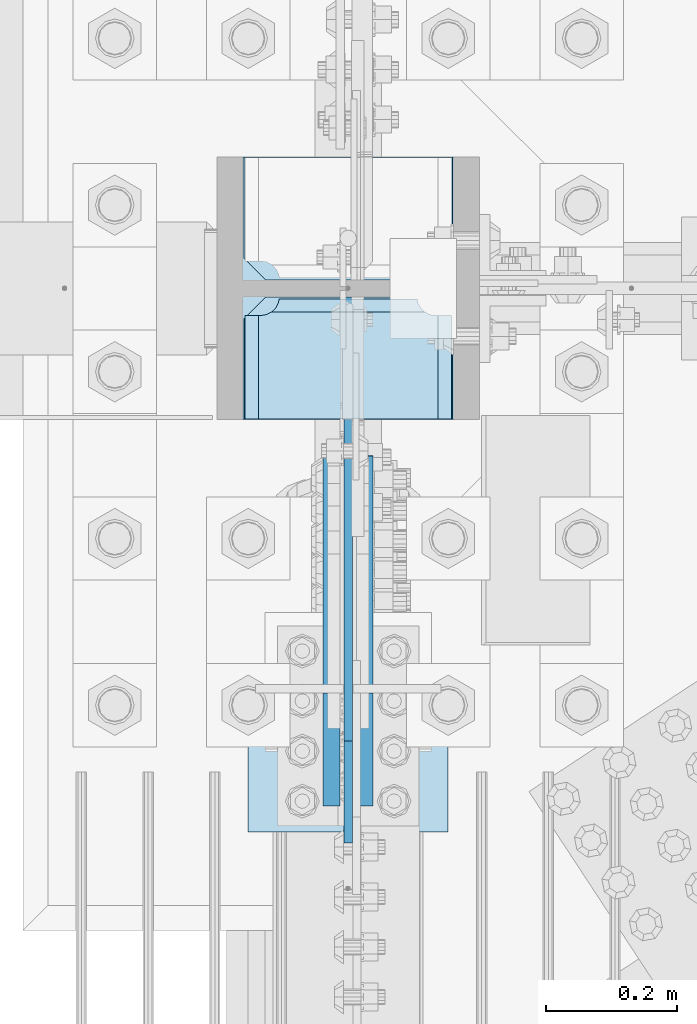
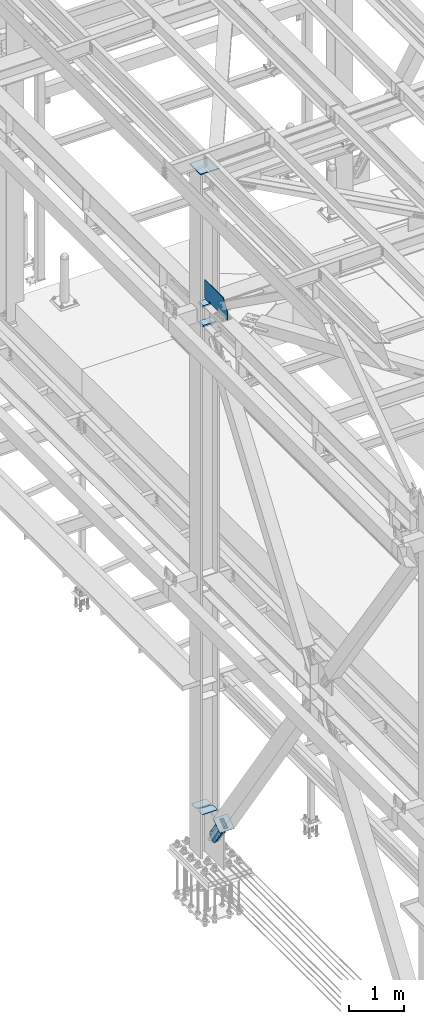
# One storey, part 3363 of 3843: 9 plates, 4 elements without a shape of their own.
"""IFC2X3 building model written with IfcOpenShell, lengths in millimetres."""

from ifc_helpers import new_model, si_unit, frame, origin_with_axes, place, context, subcontext, project, spatial, faceted_brep, material, type_object, element, aggregate, save


model = new_model("IFC2X3")

# Units and contexts
model_context = context("Model", 3, precision=1e-05, world=origin_with_axes())
body_context = subcontext(model_context, "Body", "Model", "MODEL_VIEW")
ifc_project = project(units=[si_unit("LENGTHUNIT", "METRE", prefix="MILLI"), si_unit("AREAUNIT", "SQUARE_METRE"), si_unit("VOLUMEUNIT", "CUBIC_METRE"), si_unit("MASSUNIT", "GRAM", prefix="KILO"), si_unit("TIMEUNIT", "SECOND"), si_unit("PLANEANGLEUNIT", "RADIAN"), si_unit("SOLIDANGLEUNIT", "STERADIAN"), si_unit("THERMODYNAMICTEMPERATUREUNIT", "DEGREE_CELSIUS"), si_unit("LUMINOUSINTENSITYUNIT", "LUMEN")], contexts=[model_context])

# Site, building, storey
site_placement = place(None, origin_with_axes())
site = spatial("IfcSite", under=ifc_project, at=site_placement, CompositionType="ELEMENT")
building_placement = place(site_placement, origin_with_axes())
building = spatial("IfcBuilding", under=site, at=building_placement, Name="Undefined", CompositionType="ELEMENT")
storey_placement = place(building_placement, origin_with_axes())
storey = spatial("IfcBuildingStorey", under=building, at=storey_placement, Name="Undefined", CompositionType="ELEMENT", Elevation=0.0)

# Assembly, plates
assembly_1_placement = place(storey_placement, origin_with_axes())
assembly_1 = element("IfcElementAssembly", 1, at=assembly_1_placement, inside=storey, Name="COLUMN", AssemblyPlace="NOTDEFINED", PredefinedType="RIGID_FRAME")
ifc_material_1 = material(Name="STEEL/A572-50")
plate_type_1 = type_object("IfcPlateType", PredefinedType="NOTDEFINED")
plate_1_placement = place(assembly_1_placement, frame((36575.9999999316, 75615.8000000094, 42468.7999999836), z_axis=(0.0, -1.0, 0.0), x_axis=(0.0, 0.0, 1.0)))
plate_1 = element("IfcPlate", 2, at=plate_1_placement, type_object=plate_type_1, material=ifc_material_1, Name="PLATE", context=body_context, shape_type="Brep", body=[
    faceted_brep([(19.0499992370605, -6.34999999999854, 0.0), (0.0, -6.34999999999854, 19.0499992370605), (0.0, 6.34999999999854, 19.0499992370605), (19.0499992370605, 6.34999999999854, 0.0), (25.4000002071116, -6.34999999999854, 161.925000009447), (25.4000002071116, 6.34999999999854, 161.925000009447), (0.0, 6.34999999999854, 161.925000009447), (0.0, -6.34999999999854, 161.925000009447), (30.260079725158, -6.34999999999854, 162.891729932038), (30.260079725158, 6.34999999999854, 162.891729932038), (34.3802561933117, -6.34999999999854, 165.644743832512), (34.3802561933117, 6.34999999999854, 165.644743832512), (37.1332700937855, -6.34999999999854, 169.764920300666), (37.1332700937855, 6.34999999999854, 169.764920300666), (38.1000000163767, -6.34999999999854, 174.624999818712), (38.1000000163767, 6.34999999999854, 174.624999818712), (38.1000000163767, -6.34999999999854, 200.025000200185), (38.1000000163767, 6.34999999999854, 200.025000200185), (37.1332700937855, -6.34999999999854, 204.885079718231), (37.1332700937855, 6.34999999999854, 204.885079718231), (34.3802561933117, -6.34999999999854, 209.005256186385), (34.3802561933117, 6.34999999999854, 209.005256186385), (30.260079725158, -6.34999999999854, 211.758270086859), (30.260079725158, 6.34999999999854, 211.758270086859), (25.4000002071116, -6.34999999999854, 212.72500000945), (25.4000002071116, 6.34999999999854, 212.72500000945), (12.7000000163753, -6.34999999999854, 212.72500000945), (12.7000000163753, 6.34999999999854, 212.72500000945), (12.7000000163753, -6.34999999999854, 831.912257822361), (12.7000000163753, 6.34999999999854, 831.912257822361), (209.514709617921, -6.34999999999854, 831.912257822361), (209.514709617921, 6.34999999999854, 831.912257822361), (426.693425222751, -6.34999999999854, 677.114662594795), (426.693425222751, 6.34999999999854, 677.114662594795), (426.693425222751, -6.34999999999854, 0.0), (426.693425222751, 6.34999999999854, 0.0)], [[[0, 1, 2, 3]], [[4, 5, 6, 7]], [[8, 9, 5, 4]], [[10, 11, 9, 8]], [[12, 13, 11, 10]], [[14, 15, 13, 12]], [[16, 17, 15, 14]], [[18, 19, 17, 16]], [[20, 21, 19, 18]], [[22, 23, 21, 20]], [[24, 25, 23, 22]], [[25, 24, 26, 27]], [[28, 29, 27, 26]], [[30, 31, 29, 28]], [[30, 32, 33, 31]], [[32, 34, 35, 33]], [[35, 34, 0, 3]], [[6, 5, 9, 11, 13, 15, 17, 19, 21, 23, 25, 27, 29, 31, 33, 35, 3, 2]], [[7, 6, 2, 1]], [[34, 32, 30, 28, 26, 24, 22, 20, 18, 16, 14, 12, 10, 8, 4, 7, 1, 0]]]),
])
plate_type_2 = type_object("IfcPlateType", PredefinedType="NOTDEFINED")
plate_2_placement = place(assembly_1_placement, frame((36415.6625, 75429.2687, 42013.1875), z_axis=(1.0, 0.0, 0.0), x_axis=(0.0, 1.0, 0.0)))
plate_2 = element("IfcPlate", 3, at=plate_2_placement, type_object=plate_type_2, material=ifc_material_1, Name="PLATE", context=body_context, shape_type="Brep", body=[
    faceted_brep([(169.7353359673, 6.12986484301655, 50.1051604685563), (163.413638768514, 17.0792088240414, 43.7834632697632), (163.192342336726, 17.4625000000015, 43.3491445679101), (163.192342336726, 17.4625000000015, 277.325855432093), (163.413638768514, 17.0792088240414, 276.89153673024), (169.7353359673, 6.12986484301655, 270.569839531447), (177.701139149984, -7.66711346669035, 266.511060084209), (183.356300047686, -17.4625000000015, 265.61537059048), (183.356300047686, -17.4625000000015, 55.059629409523), (177.701139149984, -7.66711346669035, 54.1639399157939), (0.0, 17.4625000000015, 297.336542336721), (0.0, -17.4625000000015, 317.500500047689), (157.956299237063, -17.4625000000015, 317.500500047689), (157.956299237063, 17.4625000000015, 297.336542336721), (157.956299237063, 17.4625000000015, 23.3384576632816), (157.956299237063, -17.4625000000015, 3.17449995231436), (0.0, -17.4625000000015, 3.17449995232164), (0.0, 17.4625000000015, 23.3384576632816), (157.956299237063, -17.4625000000015, 293.687500762942), (157.956299237063, 17.4625000000015, 293.687500762942), (159.354859321276, -17.4625000000015, 284.857339912916), (159.354859321276, 17.4625000000015, 284.857339912916), (163.413638768514, -17.4625000000015, 276.89153673024), (169.7353359673, -17.4625000000015, 270.569839531447), (177.701139149984, -17.4625000000015, 266.511060084209), (177.701139149984, -17.4625000000015, 54.1639399157939), (169.7353359673, -17.4625000000015, 50.1051604685563), (163.413638768514, -17.4625000000015, 43.7834632697632), (159.354859321276, -17.4625000000015, 35.8176600870866), (159.354859321276, 17.4625000000015, 35.8176600870866), (157.956299237063, -17.4625000000015, 26.9874992370605), (157.956299237063, 17.4625000000015, 26.9874992370605)], [[[0, 1, 2, 3, 4, 5, 6, 7, 8, 9]], [[10, 11, 12, 13]], [[14, 15, 16, 17]], [[17, 16, 11, 10]], [[18, 19, 13, 12]], [[18, 20, 21, 19]], [[21, 20, 22, 4, 3]], [[22, 23, 5, 4]], [[23, 24, 6, 5]], [[24, 7, 6]], [[25, 9, 8]], [[25, 26, 0, 9]], [[26, 27, 1, 0]], [[27, 28, 29, 2, 1]], [[28, 30, 31, 29]], [[31, 30, 15, 14]], [[29, 31, 14, 17, 10, 13, 19, 21, 3, 2]], [[15, 30, 28, 27, 26, 25, 8, 7, 24, 23, 22, 20, 18, 12, 11, 16]]]),
])
plate_3_placement = place(assembly_1_placement, frame((36415.6625, 75429.2687, 42451.3375), z_axis=(1.0, 0.0, 0.0), x_axis=(0.0, 1.0, 0.0)))
plate_3 = element("IfcPlate", 4, at=plate_3_placement, type_object=plate_type_2, material=ifc_material_1, Name="PLATE", context=body_context, shape_type="Brep", body=[
    faceted_brep([(169.7353359673, 6.12954035346047, 50.1051604685563), (163.413638768514, 17.0792088240414, 43.7834632697632), (163.192342336726, 17.4625000000015, 43.3491445679101), (163.192342336726, 17.4625000000015, 277.325855432093), (163.413638768514, 17.0792088240414, 276.89153673024), (169.7353359673, 6.12954035346047, 270.569839531447), (177.701139149984, -7.6678330078139, 266.511060084209), (183.356300047686, -17.4625000000015, 265.61537059048), (183.356300047686, -17.4625000000015, 55.059629409523), (177.701139149984, -7.6678330078139, 54.1639399157939), (0.0, 17.4625000000015, 297.336542336721), (0.0, -17.4625000000015, 317.500500047689), (157.956299237063, -17.4625000000015, 317.500500047689), (157.956299237063, 17.4625000000015, 297.336542336721), (157.956299237063, 17.4625000000015, 23.3384576632816), (157.956299237063, -17.4625000000015, 3.17449995231436), (0.0, -17.4625000000015, 3.17449995232164), (0.0, 17.4625000000015, 23.3384576632816), (157.956299237063, -17.4625000000015, 293.687500762942), (157.956299237063, 17.4625000000015, 293.687500762942), (159.354859321276, -17.4625000000015, 284.857339912916), (159.354859321276, 17.4625000000015, 284.857339912916), (163.413638768514, -17.4625000000015, 276.89153673024), (169.7353359673, -17.4625000000015, 270.569839531447), (177.701139149984, -17.4625000000015, 266.511060084209), (177.701139149984, -17.4625000000015, 54.1639399157939), (169.7353359673, -17.4625000000015, 50.1051604685563), (163.413638768514, -17.4625000000015, 43.7834632697632), (159.354859321276, -17.4625000000015, 35.8176600870866), (159.354859321276, 17.4625000000015, 35.8176600870866), (157.956299237063, -17.4625000000015, 26.9874992370605), (157.956299237063, 17.4625000000015, 26.9874992370605)], [[[0, 1, 2, 3, 4, 5, 6, 7, 8, 9]], [[10, 11, 12, 13]], [[14, 15, 16, 17]], [[17, 16, 11, 10]], [[18, 19, 13, 12]], [[18, 20, 21, 19]], [[21, 20, 22, 4, 3]], [[22, 23, 5, 4]], [[23, 24, 6, 5]], [[24, 7, 6]], [[25, 9, 8]], [[25, 26, 0, 9]], [[26, 27, 1, 0]], [[27, 28, 29, 2, 1]], [[28, 30, 31, 29]], [[31, 30, 15, 14]], [[29, 31, 14, 17, 10, 13, 19, 21, 3, 2]], [[15, 30, 28, 27, 26, 25, 8, 7, 24, 23, 22, 20, 18, 12, 11, 16]]]),
])

# Assembly, plate
assembly_2_placement = place(storey_placement, origin_with_axes())
assembly_2 = element("IfcElementAssembly", 5, at=assembly_2_placement, inside=storey, Name="Plate", AssemblyPlace="NOTDEFINED", PredefinedType="RIGID_FRAME")
ifc_material_2 = material(Name="STEEL/A36")
plate_type_3 = type_object("IfcPlateType", PredefinedType="NOTDEFINED")
plate_4_placement = place(assembly_2_placement, frame((36423.6, 74802.2806480871, 31097.2996606933), z_axis=(0.0, 0.824568408012542, 0.565762265008601), x_axis=(1.0, 0.0, 0.0)))
plate_4 = element("IfcPlate", 6, at=plate_4_placement, type_object=plate_type_3, material=ifc_material_2, Name="Plate", context=body_context, shape_type="Brep", body=[
    faceted_brep([(0.0, -3.17499999999927, 0.0), (0.0, -3.17499999999927, 304.800000000003), (0.0, 3.17499999999927, 304.800000000003), (0.0, 3.17499999999927, 0.0), (304.800000000003, -3.17500000019936, 304.800000010334), (304.800000000003, 3.17499999980646, 304.800000010323), (304.800000000003, -3.17500000000291, 2.72848410531878e-12), (304.800000000003, 3.17499999999563, -4.54747350886464e-12)], [[[0, 1, 2, 3]], [[1, 4, 5, 2]], [[4, 6, 7, 5]], [[6, 0, 3, 7]], [[5, 7, 3, 2]], [[6, 4, 1, 0]]]),
])
aggregate(assembly_2, [plate_4])

# Plate
plate_type_4 = type_object("IfcPlateType", PredefinedType="NOTDEFINED")
plate_5_placement = place(assembly_1_placement, frame((36734.75, 75641.2, 31130.1545694467), z_axis=(0.0, 1.0, 0.0), x_axis=(-1.0, 0.0, 0.0)))
plate_5 = element("IfcPlate", 7, at=plate_5_placement, type_object=plate_type_4, material=ifc_material_1, Name="CB_COL", context=body_context, shape_type="Brep", body=[
    faceted_brep([(0.0, -6.34999999999854, 33.3375015258789), (0.0, -6.34999999999854, 187.324999999997), (0.0, 6.34999999999854, 187.324999999997), (0.0, 6.34999999999854, 33.3375015258789), (317.5, -6.34999999999854, 187.324999999997), (317.5, 6.34999999999854, 187.324999999997), (317.499999999985, -6.34999999999854, 33.3375015258789), (317.499999999985, 6.34999999999854, 33.3375015258789), (284.162498474107, -6.34999999999854, 0.0), (284.162498474107, 6.34999999999854, 0.0), (33.3375015258789, -6.34999999999854, 0.0), (33.3375015258789, 6.34999999999854, 0.0)], [[[0, 1, 2, 3]], [[1, 4, 5, 2]], [[4, 6, 7, 5]], [[6, 8, 9, 7]], [[8, 10, 11, 9]], [[10, 0, 3, 11]], [[5, 7, 9, 11, 3, 2]], [[10, 8, 6, 4, 1, 0]]]),
])

plate_6_placement = place(assembly_1_placement, frame((36734.75, 75615.8, 31130.1545694467), z_axis=(0.0, -1.0, 0.0), x_axis=(-1.0, 0.0, 0.0)))
plate_6 = element("IfcPlate", 8, at=plate_6_placement, type_object=plate_type_4, material=ifc_material_1, Name="CB_COL", context=body_context, shape_type="Brep", body=[
    faceted_brep([(0.0, -6.34999999999854, 33.3375015258789), (0.0, -6.34999999999854, 187.324999999997), (0.0, 6.34999999999854, 187.324999999997), (0.0, 6.34999999999854, 33.3375015258789), (317.5, -6.34999999999854, 187.324999999997), (317.5, 6.34999999999854, 187.324999999997), (317.499999999985, -6.34999999999854, 33.3375015258789), (317.499999999985, 6.34999999999854, 33.3375015258789), (284.162498474107, -6.34999999999854, 0.0), (284.162498474107, 6.34999999999854, 0.0), (33.3375015258789, -6.34999999999854, 0.0), (33.3375015258789, 6.34999999999854, 0.0)], [[[0, 1, 2, 3]], [[1, 4, 5, 2]], [[4, 6, 7, 5]], [[6, 8, 9, 7]], [[8, 10, 11, 9]], [[10, 0, 3, 11]], [[5, 7, 9, 11, 3, 2]], [[10, 8, 6, 4, 1, 0]]]),
])

# Assembly, plate
assembly_3_placement = place(storey_placement, origin_with_axes())
assembly_3 = element("IfcElementAssembly", 9, at=assembly_3_placement, inside=storey, AssemblyPlace="NOTDEFINED", PredefinedType="RIGID_FRAME")
plate_type_5 = type_object("IfcPlateType", PredefinedType="NOTDEFINED")
plate_7_placement = place(assembly_3_placement, frame((36550.6, 75012.4555546354, 31245.35775993), z_axis=(0.0, -0.824568408012538, -0.565762265008607), x_axis=(0.0, 0.565762265008608, -0.824568408012537)))
plate_7 = element("IfcPlate", 10, at=plate_7_placement, type_object=plate_type_5, material=ifc_material_2, context=body_context, shape_type="Brep", body=[
    faceted_brep([(0.0, -12.6999999999971, 0.0), (1.66073732543737e-09, -12.6999999999971, 209.33854736769), (1.66073732543737e-09, 12.6999999999971, 209.33854736769), (0.0, 12.6999999999971, 0.0), (69.8500000003169, -12.6999999999971, 209.338547367734), (69.8500000003169, 12.6999999999971, 209.338547367734), (171.449999998262, -12.6999999999971, 218.969273686816), (171.449999998262, 12.6999999999971, 218.969273686816), (592.986744946604, -12.6999999999971, 218.969273687922), (592.986744946604, 12.6999999999971, 218.969273687922), (636.72746243389, -12.6999999999971, 210.26870402167), (636.72746243389, 12.6999999999971, 210.26870402167), (673.809052194305, -12.6999999999971, 185.491577883542), (673.809052194305, 12.6999999999971, 185.491577883542), (698.586178332225, -12.6999999999971, 148.409988122876), (698.586178332225, 12.6999999999971, 148.409988122876), (707.286747998329, -12.6999999999971, 104.669276734057), (707.286747998329, 12.6999999999971, 104.669276734057), (698.586178331945, -12.6999999999971, 60.9285592469532), (698.586178331945, 12.6999999999971, 60.9285592469532), (673.809052194054, -12.6999999999971, 23.8469694866653), (673.809052194054, 12.6999999999971, 23.8469694866653), (636.727462433904, -12.6999999999971, -0.930156651273137), (636.727462433904, 12.6999999999971, -0.930156651273137), (592.986747999643, -12.6999999999971, -9.6307263175986), (592.986747999643, 12.6999999999971, -9.6307263175986), (171.449999997149, -12.6999999999971, -9.63072631867544), (171.449999997149, 12.6999999999971, -9.63072631867544), (69.8499999986579, -12.6999999999971, 4.36557456851006e-11), (69.8499999986579, 12.6999999999971, 4.36557456851006e-11)], [[[0, 1, 2, 3]], [[1, 4, 5, 2]], [[4, 6, 7, 5]], [[6, 8, 9, 7]], [[8, 10, 11, 9]], [[10, 12, 13, 11]], [[12, 14, 15, 13]], [[14, 16, 17, 15]], [[16, 18, 19, 17]], [[18, 20, 21, 19]], [[20, 22, 23, 21]], [[22, 24, 25, 23]], [[24, 26, 27, 25]], [[26, 28, 29, 27]], [[28, 0, 3, 29]], [[5, 7, 9, 11, 13, 15, 17, 19, 21, 23, 25, 27, 29, 3, 2]], [[28, 26, 24, 22, 20, 18, 16, 14, 12, 10, 8, 6, 4, 1, 0]]]),
])
aggregate(assembly_3, [plate_7])

assembly_4_placement = place(storey_placement, origin_with_axes())
assembly_4 = element("IfcElementAssembly", 11, at=assembly_4_placement, inside=storey, AssemblyPlace="NOTDEFINED", PredefinedType="RIGID_FRAME")
plate_8_placement = place(assembly_4_placement, frame((36601.4, 75012.4555546354, 31245.35775993), z_axis=(0.0, -0.824568408012538, -0.565762265008607), x_axis=(0.0, 0.565762265008608, -0.824568408012537)))
plate_8 = element("IfcPlate", 12, at=plate_8_placement, type_object=plate_type_5, material=ifc_material_2, context=body_context, shape_type="Brep", body=[
    faceted_brep([(0.0, -12.6999999999971, 0.0), (1.66073732543737e-09, -12.6999999999971, 209.33854736769), (1.66073732543737e-09, 12.6999999999971, 209.33854736769), (0.0, 12.6999999999971, 0.0), (69.8500000003169, -12.6999999999971, 209.338547367734), (69.8500000003169, 12.6999999999971, 209.338547367734), (171.449999998262, -12.6999999999971, 218.969273686816), (171.449999998262, 12.6999999999971, 218.969273686816), (592.986744946604, -12.6999999999971, 218.969273687922), (592.986744946604, 12.6999999999971, 218.969273687922), (636.72746243389, -12.6999999999971, 210.26870402167), (636.72746243389, 12.6999999999971, 210.26870402167), (673.809052194305, -12.6999999999971, 185.491577883542), (673.809052194305, 12.6999999999971, 185.491577883542), (698.586178332225, -12.6999999999971, 148.409988122876), (698.586178332225, 12.6999999999971, 148.409988122876), (707.286747998329, -12.6999999999971, 104.669276734057), (707.286747998329, 12.6999999999971, 104.669276734057), (698.586178331945, -12.6999999999971, 60.9285592469532), (698.586178331945, 12.6999999999971, 60.9285592469532), (673.809052194054, -12.6999999999971, 23.8469694866653), (673.809052194054, 12.6999999999971, 23.8469694866653), (636.727462433904, -12.6999999999971, -0.930156651273137), (636.727462433904, 12.6999999999971, -0.930156651273137), (592.986747999643, -12.6999999999971, -9.6307263175986), (592.986747999643, 12.6999999999971, -9.6307263175986), (171.449999997149, -12.6999999999971, -9.63072631867544), (171.449999997149, 12.6999999999971, -9.63072631867544), (69.8499999986579, -12.6999999999971, 4.36557456851006e-11), (69.8499999986579, 12.6999999999971, 4.36557456851006e-11)], [[[0, 1, 2, 3]], [[1, 4, 5, 2]], [[4, 6, 7, 5]], [[6, 8, 9, 7]], [[8, 10, 11, 9]], [[10, 12, 13, 11]], [[12, 14, 15, 13]], [[14, 16, 17, 15]], [[16, 18, 19, 17]], [[18, 20, 21, 19]], [[20, 22, 23, 21]], [[22, 24, 25, 23]], [[24, 26, 27, 25]], [[26, 28, 29, 27]], [[28, 0, 3, 29]], [[5, 7, 9, 11, 13, 15, 17, 19, 21, 23, 25, 27, 29, 3, 2]], [[28, 26, 24, 22, 20, 18, 16, 14, 12, 10, 8, 6, 4, 1, 0]]]),
])
aggregate(assembly_4, [plate_8])

# Plate
plate_type_6 = type_object("IfcPlateType", PredefinedType="NOTDEFINED")
plate_9_placement = place(assembly_1_placement, frame((36776.025, 75428.4745, 45409.7962377557), z_axis=(-1.0, 0.0, 0.0), x_axis=(0.0, 1.0, 0.0)))
plate_9 = element("IfcPlate", 13, at=plate_9_placement, type_object=plate_type_6, material=ifc_material_1, Name="PLATE", context=body_context, shape_type="Brep", body=[
    faceted_brep([(0.0, -9.52500000000146, 0.0), (0.000500003050547093, -9.52500000000146, 400.049999996474), (0.000500003050547093, 9.52500000000146, 400.049999996474), (0.0, 9.52500000000146, 0.0), (400.050500003053, -9.52500000000146, 400.049999995354), (400.050500003053, 9.52500000000146, 400.049999995354), (400.049999999988, -9.52500000000146, -1.1423253454268e-09), (400.049999999988, 9.52500000000146, -1.1423253454268e-09)], [[[0, 1, 2, 3]], [[1, 4, 5, 2]], [[4, 6, 7, 5]], [[6, 0, 3, 7]], [[5, 7, 3, 2]], [[6, 4, 1, 0]]]),
])

aggregate(assembly_1, [plate_5, plate_6, plate_9, plate_2, plate_3, plate_1])

save(model, "model.ifc")
